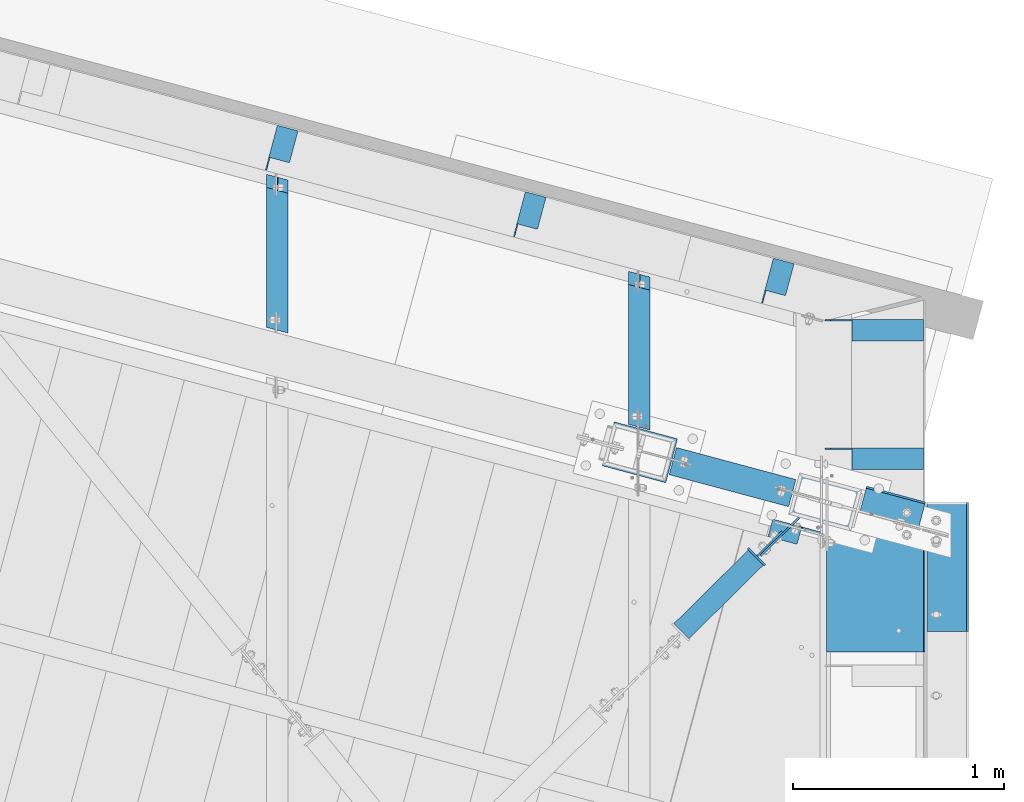
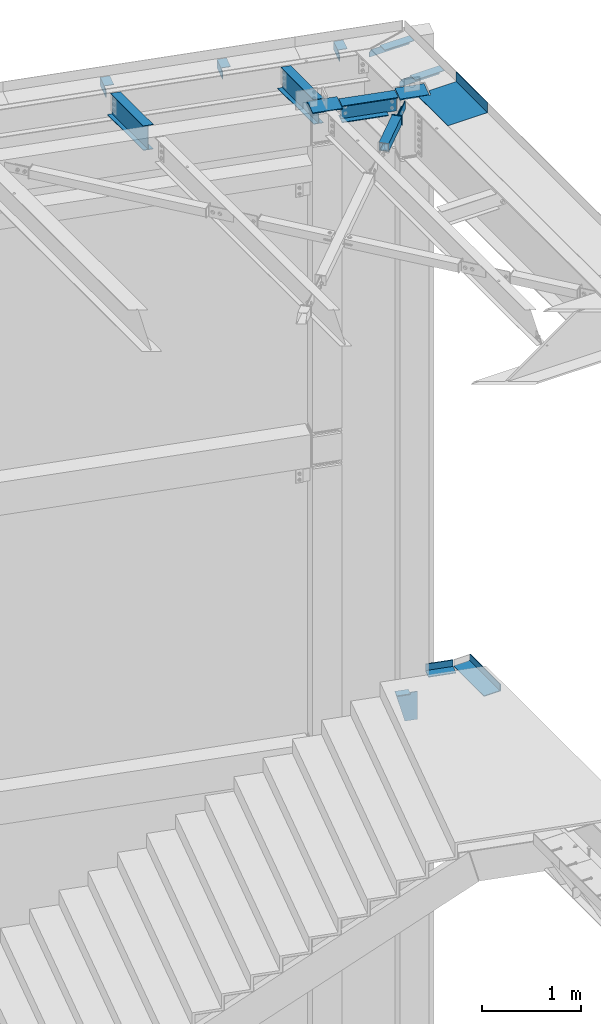
# One storey, part 1385 of 1763: 18 beams, 11 elements without a shape of their own.
"""IFC2X3 building model written with IfcOpenShell, lengths in millimetres."""

from ifc_helpers import new_model, si_unit, frame, origin_with_axes, place, context, subcontext, project, spatial, faceted_brep, material, type_object, element, aggregate, save


model = new_model("IFC2X3")

# Units and contexts
model_context = context("Model", 3, precision=1e-05, world=origin_with_axes())
body_context = subcontext(model_context, "Body", "Model", "MODEL_VIEW")
ifc_project = project(units=[si_unit("LENGTHUNIT", "METRE", prefix="MILLI"), si_unit("AREAUNIT", "SQUARE_METRE"), si_unit("VOLUMEUNIT", "CUBIC_METRE"), si_unit("MASSUNIT", "GRAM", prefix="KILO"), si_unit("TIMEUNIT", "SECOND"), si_unit("PLANEANGLEUNIT", "RADIAN"), si_unit("SOLIDANGLEUNIT", "STERADIAN"), si_unit("THERMODYNAMICTEMPERATUREUNIT", "DEGREE_CELSIUS"), si_unit("LUMINOUSINTENSITYUNIT", "LUMEN")], contexts=[model_context])

# Site, building, storey
site_placement = place(None, origin_with_axes())
site = spatial("IfcSite", under=ifc_project, at=site_placement, CompositionType="ELEMENT")
building_placement = place(site_placement, origin_with_axes())
building = spatial("IfcBuilding", under=site, at=building_placement, Name="Undefined", CompositionType="ELEMENT")
storey_placement = place(building_placement, origin_with_axes())
storey = spatial("IfcBuildingStorey", under=building, at=storey_placement, Name="Undefined", CompositionType="ELEMENT", Elevation=0.0)

# Assembly, beam
assembly_1_placement = place(storey_placement, origin_with_axes())
assembly_1 = element("IfcElementAssembly", 1, at=assembly_1_placement, inside=storey, Name="COLUMN", AssemblyPlace="NOTDEFINED", PredefinedType="RIGID_FRAME")
ifc_material_1 = material(Name="STEEL/A572-50")
beam_type_1 = type_object("IfcBeamType", PredefinedType="NOTDEFINED")
beam_1_placement = place(assembly_1_placement, frame((-22392.9908862116, 62051.4204553981, 12439.65), z_axis=(0.25886591203079, 0.965913267114842, 0.0), x_axis=(-0.965913267114846, 0.258865912030774, 0.0)))
beam_1 = element("IfcBeam", 2, at=beam_1_placement, type_object=beam_type_1, material=ifc_material_1, Name="PLATE", context=body_context, shape_type="Brep", body=[
    faceted_brep([(-7.27595761418343e-11, -6.35000000000036, -107.94999999999), (6.54836185276508e-11, -6.35000000000036, 107.949999999997), (6.54836185276508e-11, 6.35000000000036, 107.949999999997), (-7.27595761418343e-11, 6.35000000000036, -107.94999999999), (311.155237386592, -6.35000000000036, 107.949999999801), (311.155263473513, 6.35000000000036, 107.949999999801), (311.144787885874, 6.35000000000036, -107.950000000186), (311.144761798947, -6.35000000000036, -107.950000000186)], [[[0, 1, 2, 3]], [[2, 1, 4, 5]], [[3, 2, 5, 6]], [[0, 3, 6, 7]], [[1, 0, 7, 4]], [[6, 5, 4, 7]]]),
])
aggregate(assembly_1, [beam_1])

assembly_2_placement = place(storey_placement, origin_with_axes())
assembly_2 = element("IfcElementAssembly", 3, at=assembly_2_placement, inside=storey, Name="BEAM", AssemblyPlace="NOTDEFINED", PredefinedType="RIGID_FRAME")
ifc_material_2 = material(Name="STEEL/A36")
beam_type_2 = type_object("IfcBeamType", Name="L4X4X1/4", PredefinedType="NOTDEFINED")
beam_2_placement = place(assembly_2_placement, frame((-21196.9543719462, 62671.2607825527, 12395.2), z_axis=(0.0, 0.0, -1.0), x_axis=(-1.0, 0.0, 0.0)))
beam_2 = element("IfcBeam", 4, at=beam_2_placement, type_object=beam_type_2, material=ifc_material_2, Name="BRACE", ObjectType="L4X4X1/4", context=body_context, shape_type="Brep", body=[
    faceted_brep([(1.96450855582952e-10, -50.8000000000338, -44.4499999999534), (2.11002770811319e-10, -50.8000000000357, -50.799999999952), (339.73574550217, -50.8000000000029, -50.7999999999993), (339.73574550217, -50.8000000000029, -44.4500000000007), (-3.63797880709171e-11, 50.8000000000011, -50.8000000000538), (339.73574550217, 50.8000000000029, -50.7999999999993), (339.73574550217, 44.4499999999971, -34.9250007629398), (339.73574550217, 50.8000000000029, -34.9250007629398), (441.335242343601, 50.8000000000029, -34.9250007629398), (441.335242343601, 44.4499999999971, -34.9250007629398), (339.73574550217, 44.4499999999971, -44.4500000000007), (-2.18278728425503e-11, 44.4500000000007, -44.450000000048), (-1.81898940354586e-10, 44.4500000000371, 50.7999999999374), (-1.96450855582952e-10, 50.8000000000393, 50.7999999999374), (466.735245502176, 44.4499999999971, 50.7999999999993), (466.735245502176, 50.8000000000029, 50.7999999999993), (466.735241962131, 50.8000000000029, -9.52499923706091), (466.735241962131, 44.4499999999971, -9.52499923706091)], [[[0, 1, 2, 3]], [[1, 4, 5, 2]], [[6, 7, 8, 9]], [[10, 3, 2, 5, 7, 6]], [[11, 0, 3, 10]], [[1, 0, 11, 12, 13, 4]], [[13, 12, 14, 15]], [[8, 7, 5, 4, 13, 15, 16]], [[9, 8, 16, 17]], [[12, 11, 10, 6, 9, 17, 14]], [[16, 15, 14, 17]]]),
])

# Assembly, beams
assembly_3_placement = place(storey_placement, origin_with_axes())
assembly_3 = element("IfcElementAssembly", 5, at=assembly_3_placement, inside=storey, Name="BEAM", AssemblyPlace="NOTDEFINED", PredefinedType="RIGID_FRAME")
beam_3_placement = place(assembly_3_placement, frame((-24273.3098751916, 63416.5612340548, 12395.2), z_axis=(0.965993301972436, -0.258567090992627, 0.0), x_axis=(0.258567090992629, 0.965993301972436, 0.0)))
beam_3 = element("IfcBeam", 6, at=beam_3_placement, type_object=beam_type_2, material=ifc_material_2, Name="BRACE", ObjectType="L4X4X1/4", context=body_context, shape_type="Brep", body=[
    faceted_brep([(222.196628906036, 44.4500000000007, -44.4499999996697), (222.196628906255, 44.4500000000007, 50.8000000002357), (65.0605015621841, 44.4500000000007, 50.7999999998065), (65.085345901527, 44.4500000000007, -44.450000000099), (222.196628906255, 50.7999999999993, 50.8000000002357), (65.0605015621841, 50.7999999999993, 50.7999999998065), (22.2233449317646, 42.8620000839237, -44.4499999999971), (22.2250012210206, 42.8620000839237, -50.7999999999956), (3.17500133590511, 23.8120008468632, -50.7999999999593), (3.17334504664905, 23.8120008468632, -44.449999999968), (65.0853459016071, 42.8620000839237, -44.450000000099), (65.0870021908559, 42.8620000839237, -50.8000000000902), (65.0870021908268, 50.7999999999993, -50.8000000000902), (222.196628906022, 50.7999999999993, -50.7999999996609), (222.196628906036, -50.7999999999993, -44.4499999996697), (222.196628906022, -50.7999999999993, -50.7999999996609), (3.1733437935618, -50.7999999999993, -44.449999999968), (3.17500008282514, -50.7999999999993, -50.7999999999593), (3.17500133590511, 17.4619995117191, -50.7999999999593), (3.17334504664905, 17.4619995117191, -44.449999999968)], [[[0, 1, 2, 3]], [[1, 4, 5, 2]], [[6, 7, 8, 9]], [[10, 11, 7, 6]], [[2, 5, 12, 11, 10, 3]], [[4, 13, 12, 5]], [[1, 0, 14, 15, 13, 4]], [[15, 14, 16, 17]], [[8, 7, 11, 12, 13, 15, 17, 18]], [[9, 8, 18, 19]], [[14, 0, 3, 10, 6, 9, 19, 16]], [[18, 17, 16, 19]]]),
])
beam_4_placement = place(assembly_3_placement, frame((-23095.6531076327, 63101.0090548155, 12395.2), z_axis=(0.965993301972436, -0.258567090992627, 0.0), x_axis=(0.258567090992629, 0.965993301972436, 0.0)))
beam_4 = element("IfcBeam", 7, at=beam_4_placement, type_object=beam_type_2, material=ifc_material_2, Name="BRACE", ObjectType="L4X4X1/4", context=body_context, shape_type="Brep", body=[
    faceted_brep([(222.196628906036, 44.4500000000007, -44.4499999996697), (222.196628906255, 44.4500000000007, 50.8000000002357), (65.0605015621841, 44.4500000000007, 50.7999999998065), (65.085345901527, 44.4500000000007, -44.450000000099), (222.196628906255, 50.7999999999993, 50.8000000002357), (65.0605015621841, 50.7999999999993, 50.7999999998065), (22.2233449317646, 42.8620000839237, -44.4499999999971), (22.2250012210206, 42.8620000839237, -50.7999999999956), (3.17500133590511, 23.8120008468632, -50.7999999999593), (3.17334504664905, 23.8120008468632, -44.449999999968), (65.0853459016071, 42.8620000839237, -44.450000000099), (65.0870021908559, 42.8620000839237, -50.8000000000902), (65.0870021908268, 50.7999999999993, -50.8000000000902), (222.196628906022, 50.7999999999993, -50.7999999996609), (222.196628906036, -50.7999999999993, -44.4499999996697), (222.196628906022, -50.7999999999993, -50.7999999996609), (3.1733437935618, -50.7999999999993, -44.449999999968), (3.17500008282514, -50.7999999999993, -50.7999999999593), (3.17500133590511, 17.4619995117191, -50.7999999999593), (3.17334504664905, 17.4619995117191, -44.449999999968)], [[[0, 1, 2, 3]], [[1, 4, 5, 2]], [[6, 7, 8, 9]], [[10, 11, 7, 6]], [[2, 5, 12, 11, 10, 3]], [[4, 13, 12, 5]], [[1, 0, 14, 15, 13, 4]], [[15, 14, 16, 17]], [[8, 7, 11, 12, 13, 15, 17, 18]], [[9, 8, 18, 19]], [[14, 0, 3, 10, 6, 9, 19, 16]], [[18, 17, 16, 19]]]),
])
beam_5_placement = place(assembly_3_placement, frame((-21917.999767982, 62785.4440757721, 12395.2), z_axis=(0.965925826295336, -0.25881904507913, 0.0), x_axis=(0.258819045079128, 0.965925826295336, 0.0)))
beam_5 = element("IfcBeam", 8, at=beam_5_placement, type_object=beam_type_2, material=ifc_material_2, Name="BRACE", ObjectType="L4X4X1/4", context=body_context, shape_type="Brep", body=[
    faceted_brep([(222.24999495779, 44.4500000000007, -44.4499999997861), (222.249994957972, 44.4500000000007, 50.8000000000829), (65.0869999946372, 44.4500000000007, 50.7999999999811), (65.0869999946954, 44.4500000000007, -44.4499999998952), (222.249994957972, 50.7999999999993, 50.8000000000829), (65.0869999946372, 50.7999999999993, 50.7999999999811), (22.2250004826419, 42.8620000839237, -44.4499999999243), (22.2250012210206, 42.8620000839237, -50.7999999999956), (3.17500133590511, 23.8120008468632, -50.7999999999593), (3.17500124539947, 23.8120008468632, -44.4499999999389), (65.0869999947608, 42.8620000839237, -44.4499999998952), (65.0870021908559, 42.8620000839237, -50.8000000000902), (65.0870021908268, 50.7999999999993, -50.8000000000902), (222.249994957776, 50.7999999999993, -50.7999999997774), (222.24999495779, -50.7999999999993, -44.4499999997861), (222.249994957776, -50.7999999999993, -50.7999999997774), (3.17499999335269, -50.7999999999993, -44.4499999999389), (3.17500008282514, -50.7999999999993, -50.7999999999593), (3.17500133590511, 17.4619995117191, -50.7999999999593), (3.17500124539947, 17.4619995117191, -44.4499999999389)], [[[0, 1, 2, 3]], [[1, 4, 5, 2]], [[6, 7, 8, 9]], [[10, 11, 7, 6]], [[2, 5, 12, 11, 10, 3]], [[4, 13, 12, 5]], [[1, 0, 14, 15, 13, 4]], [[15, 14, 16, 17]], [[8, 7, 11, 12, 13, 15, 17, 18]], [[9, 8, 18, 19]], [[14, 0, 3, 10, 6, 9, 19, 16]], [[18, 17, 16, 19]]]),
])
aggregate(assembly_3, [beam_3, beam_4, beam_5])

# Beam
beam_6_placement = place(assembly_2_placement, frame((-21196.9543719462, 62061.6607825527, 12395.2), z_axis=(0.0, 0.0, -1.0), x_axis=(-1.0, 0.0, 0.0)))
beam_6 = element("IfcBeam", 9, at=beam_6_placement, type_object=beam_type_2, material=ifc_material_2, Name="BRACE", ObjectType="L4X4X1/4", context=body_context, shape_type="Brep", body=[
    faceted_brep([(1.96450855582952e-10, -50.8000000000338, -44.4499999999534), (2.11002770811319e-10, -50.8000000000357, -50.799999999952), (339.73574550217, -50.8000000000029, -50.7999999999993), (339.73574550217, -50.8000000000029, -44.4500000000007), (-3.63797880709171e-11, 50.8000000000011, -50.8000000000538), (339.73574550217, 50.8000000000029, -50.7999999999993), (339.73574550217, 44.4499999999971, -34.9250007629398), (339.73574550217, 50.8000000000029, -34.9250007629398), (441.335242343601, 50.8000000000029, -34.9250007629398), (441.335242343601, 44.4499999999971, -34.9250007629398), (339.73574550217, 44.4499999999971, -44.4500000000007), (-2.18278728425503e-11, 44.4500000000007, -44.450000000048), (-1.81898940354586e-10, 44.4500000000371, 50.7999999999374), (-1.96450855582952e-10, 50.8000000000393, 50.7999999999374), (466.735245502176, 44.4499999999971, 50.7999999999993), (466.735245502176, 50.8000000000029, 50.7999999999993), (466.735241962131, 50.8000000000029, -9.52499923706091), (466.735241962131, 44.4499999999971, -9.52499923706091)], [[[0, 1, 2, 3]], [[1, 4, 5, 2]], [[6, 7, 8, 9]], [[10, 3, 2, 5, 7, 6]], [[11, 0, 3, 10]], [[1, 0, 11, 12, 13, 4]], [[13, 12, 14, 15]], [[8, 7, 5, 4, 13, 15, 16]], [[9, 8, 16, 17]], [[12, 11, 10, 6, 9, 17, 14]], [[16, 15, 14, 17]]]),
])

aggregate(assembly_2, [beam_2, beam_6])

# Assembly, beam
assembly_4_placement = place(storey_placement, origin_with_axes())
assembly_4 = element("IfcElementAssembly", 10, at=assembly_4_placement, inside=storey, Name="COLUMN", AssemblyPlace="NOTDEFINED", PredefinedType="RIGID_FRAME")
beam_type_3 = type_object("IfcBeamType", PredefinedType="NOTDEFINED")
beam_7_placement = place(assembly_4_placement, frame((-21879.1751037551, 61691.1661854719, 12422.1875), z_axis=(0.711007281992602, 0.703184644992688, 0.0), x_axis=(0.0, 0.0, -1.0)))
beam_7 = element("IfcBeam", 11, at=beam_7_placement, type_object=beam_type_3, material=ifc_material_2, Name="PLATE", context=body_context, shape_type="Brep", body=[
    faceted_brep([(0.0, 4.76250000022264, -128.58749999974), (0.0, 4.76249999977153, 128.587499999725), (101.599999999999, 4.76249999977153, 128.587499999725), (101.599999999999, 4.76250000022264, -128.58749999974), (0.0, -4.76250000022992, 128.587499999732), (101.599999999999, -4.76250000022992, 128.587499999732), (0.0, -4.76249999977153, -128.587499999729), (101.599999999999, -4.76249999977153, -128.587499999729)], [[[0, 1, 2, 3]], [[1, 4, 5, 2]], [[4, 6, 7, 5]], [[6, 0, 3, 7]], [[5, 7, 3, 2]], [[6, 4, 1, 0]]]),
])

# Assembly, beams
assembly_5_placement = place(storey_placement, origin_with_axes())
assembly_5 = element("IfcElementAssembly", 12, at=assembly_5_placement, inside=storey, Name="H. BRACE", AssemblyPlace="NOTDEFINED", PredefinedType="RIGID_FRAME")
beam_8_placement = place(assembly_5_placement, frame((-21927.358411819, 61656.9094865737, 12422.1875), z_axis=(0.711007281992602, 0.703184644992688, 0.0), x_axis=(0.0, 0.0, -1.0)))
beam_8 = element("IfcBeam", 13, at=beam_8_placement, type_object=beam_type_3, material=ifc_material_2, Name="PLATE", context=body_context, shape_type="Brep", body=[
    faceted_brep([(0.0, 4.7625000001417, -82.5500000001048), (0.0, 4.76249999986885, 82.5500000001339), (101.599999999999, 4.76249999986885, 82.5500000001339), (101.599999999999, 4.7625000001417, -82.5500000001048), (0.0, -4.76250000014352, 82.5500000001193), (101.599999999999, -4.76250000014352, 82.5500000001193), (0.0, -4.76249999987067, -82.5500000001193), (101.599999999999, -4.76249999987067, -82.5500000001193)], [[[0, 1, 2, 3]], [[1, 4, 5, 2]], [[4, 6, 7, 5]], [[6, 0, 3, 7]], [[5, 7, 3, 2]], [[6, 4, 1, 0]]]),
])
ifc_material_3 = material()
beam_type_4 = type_object("IfcBeamType", Name="HSS4X4X3/8", PredefinedType="NOTDEFINED")
beam_9_placement = place(assembly_5_placement, frame((-22546.3296174484, 61044.7483195672, 12371.3875), z_axis=(0.0, 0.0, 1.0), x_axis=(0.711007281992602, 0.703184644992688, 0.0)))
beam_9 = element("IfcBeam", 14, at=beam_9_placement, type_object=beam_type_4, material=ifc_material_3, Name="H. BRACE", ObjectType="HSS4X4X3/8", context=body_context, shape_type="Brep", body=[
    faceted_brep([(280.742643682952, 41.2749999995285, -41.2749999999996), (280.742643683163, -41.275000000518, -41.2749999999996), (778.480367442055, -41.2750000013984, -41.2749999999996), (778.480367441844, 41.2749999986336, -41.2749999999996), (280.742643683163, -41.275000000518, 41.2749999999996), (778.480367442055, -41.2750000013984, 41.2749999999996), (280.742643682952, 41.2749999995285, 41.2749999999996), (778.480367441844, 41.2749999986336, 41.2749999999996), (280.742643682926, 50.7999999995227, -50.7999999999993), (280.742643682926, 50.7999999995227, 50.7999999999993), (778.480367441818, 50.7999999986423, 50.7999999999993), (778.480367441818, 50.7999999986423, -50.7999999999993), (280.742643683188, -50.8000000005195, 50.7999999999993), (778.48036744208, -50.8000000014072, 50.7999999999993), (280.742643683188, -50.8000000005195, -50.7999999999993), (778.48036744208, -50.8000000014072, -50.7999999999993)], [[[0, 1, 2, 3]], [[1, 4, 5, 2]], [[4, 6, 7, 5]], [[6, 0, 3, 7]], [[8, 9, 10, 11]], [[9, 12, 13, 10]], [[12, 14, 15, 13]], [[14, 8, 11, 15]], [[13, 15, 11, 10], [5, 7, 3, 2]], [[14, 12, 9, 8], [6, 4, 1, 0]]]),
])
beam_type_5 = type_object("IfcBeamType", PredefinedType="NOTDEFINED")
beam_10_placement = place(assembly_5_placement, frame((-21989.4382351284, 61595.512677258, 12428.5375), z_axis=(-0.703184644992684, 0.711007281992605, 0.0), x_axis=(0.0, 0.0, -1.0)))
beam_10 = element("IfcBeam", 15, at=beam_10_placement, type_object=beam_type_5, material=ifc_material_2, Name="PLATE", context=body_context, shape_type="Brep", body=[
    faceted_brep([(0.0, 4.76249999989523, -57.1500000001702), (0.0, 4.76250000014261, 57.1500000001565), (114.299999999999, 4.76250000014261, 57.1500000001565), (114.299999999999, 4.76249999989523, -57.1500000001702), (0.0, -4.76249999988067, 57.1500000001784), (114.299999999999, -4.76249999988067, 57.1500000001784), (0.0, -4.76250000012806, -57.150000000152), (114.299999999999, -4.76250000012806, -57.150000000152)], [[[0, 1, 2, 3]], [[1, 4, 5, 2]], [[4, 6, 7, 5]], [[6, 0, 3, 7]], [[5, 7, 3, 2]], [[6, 4, 1, 0]]]),
])
aggregate(assembly_5, [beam_10, beam_8, beam_9])

# Assembly, beam
assembly_6_placement = place(storey_placement, origin_with_axes())
assembly_6 = element("IfcElementAssembly", 16, at=assembly_6_placement, inside=storey, Name="BEAM", AssemblyPlace="NOTDEFINED", PredefinedType="RIGID_FRAME")
beam_type_6 = type_object("IfcBeamType", PredefinedType="NOTDEFINED")
beam_11_placement = place(assembly_6_placement, frame((-21358.3332559334, 61775.8942308848, 5199.0625), z_axis=(0.965925826295336, -0.25881904507913, 0.0), x_axis=(0.258819045079128, 0.965925826295336, 0.0)))
beam_11 = element("IfcBeam", 17, at=beam_11_placement, type_object=beam_type_6, material=ifc_material_2, Name="BENT PLATE", context=body_context, shape_type="Brep", body=[
    faceted_brep([(8.00355337560177e-11, -4.76249999999982, -144.4624999999), (-8.00355337560177e-11, -4.76249999999982, 144.4624999999), (-8.00355337560177e-11, 4.76249999999982, 144.4624999999), (8.00355337560177e-11, 4.76249999999982, -144.4624999999), (111.75567886106, 4.76249999999982, 144.462499999565), (111.755678860478, 4.76249999999982, -144.462500000234), (121.280678860465, -4.76249999999982, -144.462500000263), (121.280678861047, -4.76249999999982, 144.462499999543), (111.755678860689, 84.1374939169427, 144.462499999354), (111.755678860849, 84.1374939162042, -144.462500000453), (121.280678860676, 84.1374939169427, 144.462499999325), (121.280678860836, 84.1374939162042, -144.462500000482)], [[[0, 1, 2, 3]], [[3, 2, 4, 5]], [[1, 0, 6, 7]], [[5, 4, 8, 9]], [[4, 2, 1, 7, 10, 8]], [[7, 6, 11, 10]], [[6, 0, 3, 5, 9, 11]], [[10, 11, 9, 8]]]),
])

assembly_7_placement = place(storey_placement, origin_with_axes())
assembly_7 = element("IfcElementAssembly", 18, at=assembly_7_placement, inside=storey, Name="BEAM", AssemblyPlace="NOTDEFINED", PredefinedType="RIGID_FRAME")
beam_type_7 = type_object("IfcBeamType", PredefinedType="NOTDEFINED")
beam_12_placement = place(assembly_7_placement, frame((-21657.3396174483, 61459.4215, 12449.175), z_axis=(0.0, -1.0, 0.0), x_axis=(1.0, 0.0, 0.0)))
beam_12 = element("IfcBeam", 19, at=beam_12_placement, type_object=beam_type_7, material=ifc_material_2, Name="BENT_PLATE", context=body_context, shape_type="Brep", body=[
    faceted_brep([(0.0, -3.17499999999927, -276.555830670608), (0.0, 3.17499999999927, -276.555830670608), (123.543906469818, 3.17499999999927, -243.445915823286), (123.543906469818, -3.17500000001201, -243.445915823286), (142.79324902263, -3.17500000001201, -315.271500000003), (142.79324902263, 3.17499999999927, -315.271500000003), (460.375006103517, 3.17499999999927, 315.271500000003), (0.0, 3.17499999999927, 315.271500000003), (0.0, -3.17499999999927, 315.271500000003), (466.725006103516, -3.17499999999927, 315.271500000003), (466.725006103516, 123.825000000001, 315.271500000003), (460.375006103517, 123.825000000001, 315.271500000003), (460.375006103517, 3.17499999999927, -315.271500000003), (460.375006103517, 123.825000000001, -315.271500000003), (466.725006103516, 123.825000000001, -315.271500000003), (466.725006103516, -3.17499999999927, -315.271500000003)], [[[0, 1, 2, 3]], [[4, 3, 2, 5]], [[6, 7, 8, 9, 10, 11]], [[12, 6, 11, 13]], [[10, 14, 13, 11]], [[9, 15, 14, 10]], [[12, 13, 14, 15, 4, 5]], [[1, 7, 6, 12, 5, 2]], [[8, 7, 1, 0]], [[15, 9, 8, 0, 3, 4]]]),
])
aggregate(assembly_7, [beam_12])

# Beam
beam_type_8 = type_object("IfcBeamType", PredefinedType="NOTDEFINED")
beam_13_placement = place(assembly_4_placement, frame((-21516.4744355416, 61816.5588992879, 12438.0625), z_axis=(0.25886591203079, 0.965913267114842, 0.0), x_axis=(-0.965913267114846, 0.258865912030774, 0.0)))
beam_13 = element("IfcBeam", 20, at=beam_13_placement, type_object=beam_type_8, material=ifc_material_1, Name="PLATE", context=body_context, shape_type="Brep", body=[
    faceted_brep([(-5.82076609134674e-11, 7.9375, -101.599999999991), (0.0, 7.9375, 101.599998474121), (304.799999999937, 7.9375, 101.599999999809), (304.799999999814, 7.9375, -101.60000000018), (0.0, -7.9375, 101.599998474121), (304.799999999937, -7.9375, 101.599999999809), (-5.82076609134674e-11, -7.9375, -101.599999999991), (304.799999999814, -7.9375, -101.60000000018)], [[[0, 1, 2, 3]], [[1, 4, 5, 2]], [[4, 6, 7, 5]], [[6, 0, 3, 7]], [[5, 7, 3, 2]], [[6, 4, 1, 0]]]),
])

aggregate(assembly_4, [beam_7, beam_13])

# Assembly, beam
assembly_8_placement = place(storey_placement, origin_with_axes())
assembly_8 = element("IfcElementAssembly", 21, at=assembly_8_placement, inside=storey, Name="STRINGER", AssemblyPlace="NOTDEFINED", PredefinedType="RIGID_FRAME")
beam_type_9 = type_object("IfcBeamType", Name="C15X33.9", PredefinedType="NOTDEFINED")
beam_14_placement = place(assembly_8_placement, frame((-21588.3387064968, 61643.2429973115, 5003.79999999962), z_axis=(0.0, 0.0, -1.0), x_axis=(-0.965913267114846, 0.258865912030774, 0.0)))
beam_14 = element("IfcBeam", 22, at=beam_14_placement, type_object=beam_type_9, material=ifc_material_2, Name="STRINGER", ObjectType="C15X33.9", context=body_context, shape_type="Brep", body=[
    faceted_brep([(250.009238429986, 33.3374999998487, 169.0709725), (244.215919231217, 33.3374999998414, 190.5), (109.667816043569, 33.3374999999287, 190.5), (109.667816043569, 33.337499999936, 169.0709725), (109.667816043569, 33.337499999936, -152.400001525879), (109.667816043577, 42.8624999999229, -152.400001525879), (192.217816234304, 42.8624999998792, -152.400001525879), (192.217816234304, 33.3374999998778, -152.400001525879), (197.077895752351, 42.8624999998792, -153.366731448466), (197.077895752343, 33.3374999998705, -153.366731448466), (201.198072220504, 42.8624999998719, -156.119745348945), (201.198072220504, 33.3374999998778, -156.119745348945), (203.951086120986, 42.8624999998792, -160.239921817099), (203.951086120978, 33.3374999998705, -160.239921817099), (204.917816043569, 42.8624999998719, -165.100001335144), (204.917816043569, 33.3374999998705, -165.100001335144), (109.667816043577, 42.8624999999229, 190.5), (244.215919231225, 42.8624999998501, 190.5), (347.218942337553, 42.8624999997846, -190.5), (204.917816043569, 42.8624999998719, -190.5), (347.218942337553, -42.8625000002139, -190.5), (204.917816043519, -42.8625000001193, -190.5), (344.857683868693, -42.8625000002066, -181.7658925), (204.917816043519, -42.8625000001193, -181.7658925), (341.425623138784, 33.3374999997832, -169.0709725), (204.917816043569, 33.3374999998705, -169.0709725), (254.516221129335, 33.3374999998487, 152.400001525878), (109.667816043569, 33.337499999936, 152.400001525878)], [[[0, 1, 2, 3]], [[4, 5, 6, 7]], [[7, 6, 8, 9]], [[9, 8, 10, 11]], [[11, 10, 12, 13]], [[13, 12, 14, 15]], [[10, 8, 6, 5, 16, 17, 18, 19, 14, 12]], [[18, 20, 21, 19]], [[20, 22, 23, 21]], [[22, 24, 25, 23]], [[15, 14, 19, 21, 23, 25]], [[24, 26, 0, 3, 27, 4, 7, 9, 11, 13, 15, 25]], [[16, 5, 4, 27, 3, 2]], [[17, 16, 2, 1]], [[26, 24, 22, 20, 18, 17, 1, 0]]]),
])
aggregate(assembly_8, [beam_14])

# Beam
beam_type_10 = type_object("IfcBeamType", PredefinedType="NOTDEFINED")
beam_15_placement = place(assembly_6_placement, frame((-21181.0896174484, 61547.573438, 5199.0625), z_axis=(0.0, -1.0, 0.0), x_axis=(1.0, 0.0, 0.0)))
beam_15 = element("IfcBeam", 23, at=beam_15_placement, type_object=beam_type_10, material=ifc_material_2, Name="BENT PLATE", context=body_context, shape_type="Brep", body=[
    faceted_brep([(0.0, -4.76249999999982, -306.387499999997), (0.0, -4.76249999999982, 306.387499999997), (0.0, 4.76249999999982, 306.387499999997), (0.0, 4.76249999999982, -306.387499999997), (187.325021362303, 4.76249999999982, 306.387499999997), (187.325021362303, 4.76249999999982, -306.387499999997), (196.850021362305, -4.76249999999982, -306.387499999997), (196.850021362305, -4.76249999999982, 306.387499999997), (187.325021362303, 84.1374938964846, 306.387499999997), (187.325021362303, 84.1374938964846, -306.387499999997), (196.850021362305, 84.1374938964846, 306.387499999997), (196.850021362305, 84.1374938964846, -306.387499999997)], [[[0, 1, 2, 3]], [[3, 2, 4, 5]], [[1, 0, 6, 7]], [[5, 4, 8, 9]], [[4, 2, 1, 7, 10, 8]], [[7, 6, 11, 10]], [[6, 0, 3, 5, 9, 11]], [[10, 11, 9, 8]]]),
])

aggregate(assembly_6, [beam_11, beam_15])

# Assembly, beam
assembly_9_placement = place(storey_placement, origin_with_axes())
assembly_9 = element("IfcElementAssembly", 24, at=assembly_9_placement, inside=storey, Name="BEAM", AssemblyPlace="NOTDEFINED", PredefinedType="RIGID_FRAME")
ifc_material_4 = material(Name="STEEL/A992")
beam_type_11 = type_object("IfcBeamType", Name="W12X16", PredefinedType="NOTDEFINED")
beam_16_placement = place(assembly_9_placement, frame((-22546.3296174484, 62094.2195758187, 12293.6), z_axis=(0.0, 0.0, 1.0), x_axis=(0.0, 1.0, 0.0)))
beam_16 = element("IfcBeam", 25, at=beam_16_placement, type_object=beam_type_11, material=ifc_material_4, Name="BEAM", ObjectType="W12X16", context=body_context, shape_type="Brep", body=[
    faceted_brep([(794.308752797668, 50.7999999999993, 152.4), (767.085114849222, -50.7999999999993, 152.4), (767.085114849222, -50.7999999999993, 146.049999999999), (779.846195137558, -3.17499999999927, 146.049999999999), (779.846195137397, -3.17499999999927, 126.999999809264), (781.547672509158, 3.17499999999927, 126.999999809264), (781.547672509332, 3.17499999999927, 146.049999999999), (794.308752797668, 50.7999999999993, 146.049999999999), (780.847027599142, -3.17499999999927, 122.139920291218), (782.548504970902, 3.17499999999927, 122.139920291218), (783.697157314629, -3.17499999999927, 118.019743823064), (785.398634686389, 3.17499999999927, 118.019743823064), (787.962677871183, -3.17499999999927, 115.266729922587), (789.664155242943, 3.17499999999927, 115.266729922587), (792.994202431095, -3.17499999999927, 114.299999999999), (794.695679802855, 3.17499999999927, 114.299999999999), (844.000705004772, 3.17499999999927, 114.299999999999), (842.299227632997, -3.17499999999927, 114.299999999999), (115.77854535474, -3.17499999999927, -146.049999999999), (103.014988335497, -50.7999999999993, -146.049999999999), (829.538147344698, -50.7999999999993, -146.049999999999), (842.299227632997, -3.17499999999927, -146.049999999999), (103.014988335497, -50.7999999999993, -152.4), (829.538147344698, -50.7999999999993, -152.4), (130.243909976554, 50.7999999999993, -152.4), (856.761785293063, 50.7999999999993, -152.4), (130.243909976554, 50.7999999999993, -146.049999999999), (856.761785293063, 50.7999999999993, -146.049999999999), (115.77854535474, -3.17499999999927, 146.049999999999), (103.014988335497, -50.7999999999993, 146.049999999999), (103.014988335497, -50.7999999999993, 152.4), (130.243909976554, 50.7999999999993, 152.4), (130.243909976554, 50.7999999999993, 146.049999999999), (117.480352957311, 3.17499999999927, 146.049999999999), (117.480352957311, 3.17499999999927, -146.049999999999), (844.000705004772, 3.17499999999927, -146.049999999999)], [[[0, 1, 2, 3, 4, 5, 6, 7]], [[5, 4, 8, 9]], [[9, 8, 10, 11]], [[11, 10, 12, 13]], [[13, 12, 14, 15]], [[16, 15, 14, 17]], [[18, 19, 20, 21]], [[19, 22, 23, 20]], [[22, 24, 25, 23]], [[24, 26, 27, 25]], [[22, 19, 18, 28, 29, 30, 31, 32, 33, 34, 26, 24]], [[26, 34, 35, 27]], [[21, 20, 23, 25, 27, 35, 16, 17]], [[12, 10, 8, 4, 3, 28, 18, 21, 17, 14]], [[29, 28, 3, 2]], [[30, 29, 2, 1]], [[31, 30, 1, 0]], [[32, 31, 0, 7]], [[33, 32, 7, 6]], [[35, 34, 33, 6, 5, 9, 11, 13, 15, 16]]]),
])
aggregate(assembly_9, [beam_16])

assembly_10_placement = place(storey_placement, origin_with_axes())
assembly_10 = element("IfcElementAssembly", 26, at=assembly_10_placement, inside=storey, Name="BEAM", AssemblyPlace="NOTDEFINED", PredefinedType="RIGID_FRAME")
beam_17_placement = place(assembly_10_placement, frame((-24264.6496174484, 62552.9378752486, 12293.6), z_axis=(0.0, 0.0, 1.0), x_axis=(0.0, 1.0, 0.0)))
beam_17 = element("IfcBeam", 27, at=beam_17_placement, type_object=beam_type_11, material=ifc_material_4, Name="BEAM", ObjectType="W12X16", context=body_context, shape_type="Brep", body=[
    faceted_brep([(117.481328757029, -3.17499999999927, -146.049999999999), (104.720248468737, -50.7999999999993, -146.049999999999), (831.242304197956, -50.7999999999993, -146.049999999999), (844.003384486256, -3.17499999999927, -146.049999999999), (104.720248468737, -50.7999999999993, -152.4), (831.242304197956, -50.7999999999993, -152.4), (131.943886417102, 50.7999999999993, -152.4), (858.465942146322, 50.7999999999993, -152.4), (131.943886417102, 50.7999999999993, -146.049999999999), (119.182806128803, 3.17499999999927, -146.049999999999), (845.704861858023, 3.17499999999927, -146.049999999999), (858.465942146322, 50.7999999999993, -146.049999999999), (845.704861858023, 3.17499999999927, 114.299999999999), (844.003384486256, -3.17499999999927, 114.299999999999), (117.481328757029, -3.17499999999927, 146.049999999999), (104.720248468737, -50.7999999999993, 146.049999999999), (104.720248468737, -50.7999999999993, 152.4), (131.943886417102, 50.7999999999993, 152.4), (131.943886417102, 50.7999999999993, 146.049999999999), (119.182806128803, 3.17499999999927, 146.049999999999), (783.25182938738, 3.17499999999927, 146.049999999999), (783.251829387205, 3.17499999999927, 126.999999809264), (784.252661848943, 3.17499999999927, 122.139920291218), (787.102791564437, 3.17499999999927, 118.019743823064), (791.368312120983, 3.17499999999927, 115.266729922587), (796.399836680896, 3.17499999999927, 114.299999999999), (781.550352015445, -3.17499999999927, 126.999999809264), (782.551184477183, -3.17499999999927, 122.139920291218), (785.401314192677, -3.17499999999927, 118.019743823064), (789.666834749223, -3.17499999999927, 115.266729922587), (794.698359309135, -3.17499999999927, 114.299999999999), (781.550352015598, -3.17499999999927, 146.049999999999), (768.78927172727, -50.7999999999993, 146.049999999999), (768.78927172727, -50.7999999999993, 152.4), (796.012909675708, 50.7999999999993, 152.4), (796.012909675708, 50.7999999999993, 146.049999999999)], [[[0, 1, 2, 3]], [[1, 4, 5, 2]], [[4, 6, 7, 5]], [[8, 9, 10, 11]], [[3, 2, 5, 7, 11, 10, 12, 13]], [[6, 8, 11, 7]], [[4, 1, 0, 14, 15, 16, 17, 18, 19, 9, 8, 6]], [[10, 9, 19, 20, 21, 22, 23, 24, 25, 12]], [[21, 26, 27, 22]], [[22, 27, 28, 23]], [[23, 28, 29, 24]], [[24, 29, 30, 25]], [[12, 25, 30, 13]], [[29, 28, 27, 26, 31, 14, 0, 3, 13, 30]], [[15, 14, 31, 32]], [[16, 15, 32, 33]], [[17, 16, 33, 34]], [[18, 17, 34, 35]], [[19, 18, 35, 20]], [[34, 33, 32, 31, 26, 21, 20, 35]]]),
])
aggregate(assembly_10, [beam_17])

assembly_11_placement = place(storey_placement, origin_with_axes())
assembly_11 = element("IfcElementAssembly", 28, at=assembly_11_placement, inside=storey, Name="BEAM", AssemblyPlace="NOTDEFINED", PredefinedType="RIGID_FRAME")
beam_type_12 = type_object("IfcBeamType", Name="W8X21", PredefinedType="NOTDEFINED")
beam_18_placement = place(assembly_11_placement, frame((-22552.6896174484, 62094.2195758187, 12341.225), z_axis=(0.0, 0.0, 1.0), x_axis=(0.965925826295336, -0.25881904507913, 0.0)))
beam_18 = element("IfcBeam", 29, at=beam_18_placement, type_object=beam_type_12, material=ifc_material_4, Name="BEAM", ObjectType="W8X21", context=body_context, shape_type="Brep", body=[
    faceted_brep([(656.846032642323, -66.6749999989624, -95.25), (656.846032642323, -66.6749999989624, -104.775), (656.846031183042, -3.17992976304231, -104.775), (656.846031183049, -3.174999998766, -95.25), (758.44911205188, -3.17992975994275, -95.25), (758.445722653676, -3.17992959548428, -104.775), (171.684202733028, -3.17499999969004, -95.25), (171.681121677677, -66.6749999998865, -95.25), (171.681121677677, -66.6749999998865, -104.775), (171.687591893911, 66.6750000005341, -95.25), (171.684510838561, 3.17500000034488, -95.25), (656.846032642366, 3.17500000125438, -95.25), (656.846031183086, 66.6750000014581, -95.25), (171.681121677677, -66.6749999998865, 104.775), (171.681121677677, -66.6749999998865, 95.25), (758.442641837515, -66.6749999987733, 95.25), (758.442641837515, -66.6749999987733, 104.775), (171.687591893911, 66.6750000005341, 104.775), (758.44911205375, 66.6750000016473, 104.775), (171.687591893911, 66.6750000005341, 95.25), (758.44911205375, 66.6750000016473, 95.25), (171.684510838561, 3.17500000034488, 95.25), (758.446030998399, 3.17500000145083, 95.25), (758.446030998399, 3.17500000145083, -57.1500000000142), (758.446030996682, 3.1750000783577, -95.25), (758.446030998399, 3.1750000783577, -104.775), (656.846032642366, 3.17992976625828, -104.775), (171.687591893911, 66.6750000005341, -104.775), (656.846031183086, 66.6750000014581, -104.775), (171.684202733028, -3.17499999969004, 95.25), (758.445722892866, -3.17499999856955, 95.25), (758.445722892866, -3.17499999856955, -57.1499999999814)], [[[0, 1, 2, 3]], [[4, 3, 2, 5]], [[6, 7, 0, 3]], [[7, 8, 1, 0]], [[9, 10, 11, 12]], [[13, 14, 15, 16]], [[17, 13, 16, 18]], [[19, 17, 18, 20]], [[21, 19, 20, 22]], [[11, 10, 21, 22, 23, 24]], [[24, 25, 26, 11]], [[1, 8, 27, 28, 26, 25, 5, 2]], [[11, 26, 28, 12]], [[27, 9, 12, 28]], [[8, 7, 6, 29, 14, 13, 17, 19, 21, 10, 9, 27]], [[14, 29, 30, 15]], [[25, 24, 23, 22, 20, 18, 16, 15, 30, 31, 4, 5]], [[29, 6, 3, 4, 31, 30]]]),
])
aggregate(assembly_11, [beam_18])

save(model, "model.ifc")
